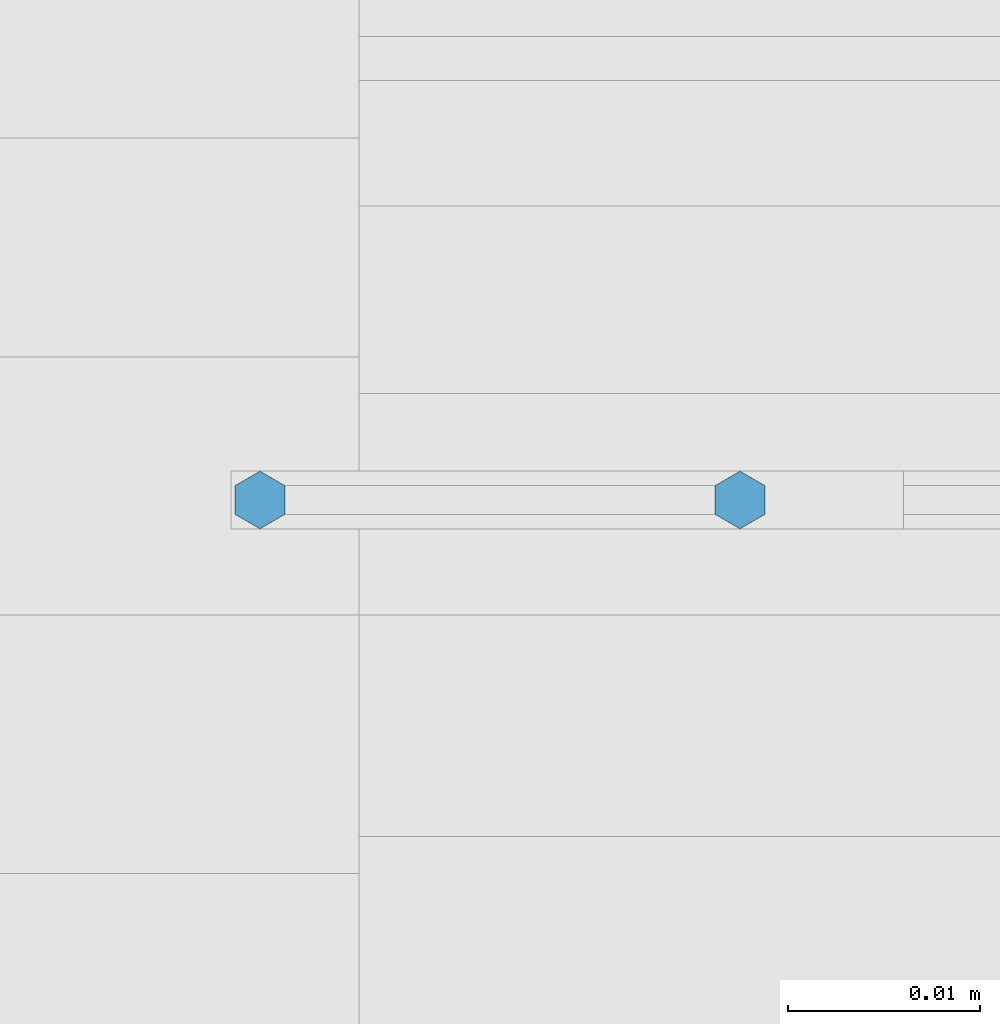
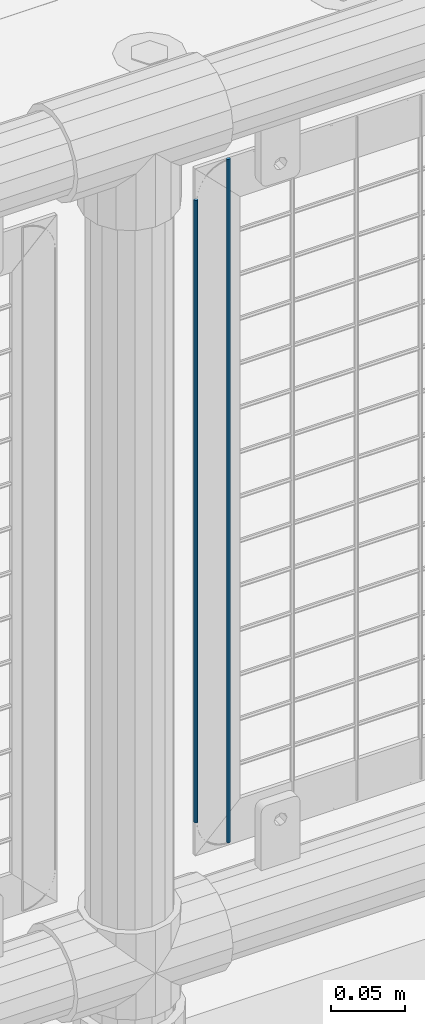
# One storey, part 80 of 257: 2 columns.
"""IFC2X3 building model written with IfcOpenShell, lengths in millimetres."""

import ifcopenshell
import ifcopenshell.guid

model = None  # the IFC model being written
_history = None  # IfcOwnerHistory: only IFC2X3 demands one
_inside = {}  # id of a spatial element -> (the spatial element, [elements in it])
_under = {}  # id of a project, library or spatial element -> (it, [spatial elements below it])
_declared = {}  # id of a project -> (the project, [libraries it declares])
_typed = {}  # id of a type object -> (the type object, [elements of that type])
_made_of = {}  # id of a material, layer set ... -> (it, [elements and type objects made of it])


def new_model(schema):
    """Start an empty IFC model of exactly this schema.

    Asked for "IFC4X3", IfcOpenShell would pick the latest addendum, in which some entities
    have other attributes; the version numbers below select the first issue.
    IFC2X3 requires an IfcOwnerHistory on every rooted entity: one is made here for all.
    """
    global model, _history
    if schema == "IFC4X3":
        model = ifcopenshell.file(schema_version=(4, 3, 0, 0))
    else:
        model = ifcopenshell.file(schema=schema)
    _inside.clear()
    _under.clear()
    _declared.clear()
    _typed.clear()
    _made_of.clear()
    _history = None
    if model.schema == "IFC2X3":
        org = make("IfcOrganization", Name="unknown")
        user = make(
            "IfcPersonAndOrganization",
            ThePerson=make("IfcPerson", FamilyName="unknown"),
            TheOrganization=org,
        )
        app = make(
            "IfcApplication",
            ApplicationDeveloper=org,
            Version="unknown",
            ApplicationFullName="unknown",
            ApplicationIdentifier="unknown",
        )
        _history = make(
            "IfcOwnerHistory",
            OwningUser=user,
            OwningApplication=app,
            ChangeAction="ADDED",
            CreationDate=0,
        )
    return model


def make(cls, **values):
    """One entity of the class cls with the attributes given. An attribute that is None is left unset."""
    return model.create_entity(
        cls, **{name: value for name, value in values.items() if value is not None}
    )


def rooted(cls, **values):
    """An entity with a GlobalId (a new one), such as an element, a storey or a relation."""
    return make(cls, GlobalId=ifcopenshell.guid.new(), OwnerHistory=_history, **values)


def si_unit(unit_type, name, prefix=None):
    """IfcSIUnit, for example si_unit("LENGTHUNIT", "METRE", prefix="MILLI")."""
    return make("IfcSIUnit", UnitType=unit_type, Prefix=prefix, Name=name)


def assignment(units):
    """IfcUnitAssignment: the units of a project."""
    return None if units is None else make("IfcUnitAssignment", Units=units)


def point(xyz):
    """IfcCartesianPoint."""
    return None if xyz is None else make("IfcCartesianPoint", Coordinates=xyz)


def direction(xyz):
    """IfcDirection."""
    return None if xyz is None else make("IfcDirection", DirectionRatios=xyz)


def frame(location, z_axis=None, x_axis=None):
    """IfcAxis2Placement3D, a coordinate frame: its origin and axes. An axis left out is left unset."""
    return make(
        "IfcAxis2Placement3D",
        Location=point(location),
        Axis=direction(z_axis),
        RefDirection=direction(x_axis),
    )


def origin_with_axes():
    """The frame at (0, 0, 0) with the z axis (0, 0, 1) and the x axis (1, 0, 0) written out."""
    return frame((0.0, 0.0, 0.0), z_axis=(0.0, 0.0, 1.0), x_axis=(1.0, 0.0, 0.0))


def place(relative_to, where):
    """IfcLocalPlacement: puts the frame where relative to a parent placement (None: the world)."""
    return make(
        "IfcLocalPlacement", PlacementRelTo=relative_to, RelativePlacement=where
    )


def context(
    kind, dimensions, precision=None, world=None, true_north=None, identifier=None
):
    """IfcGeometricRepresentationContext, for example the 3D "Model" context."""
    return make(
        "IfcGeometricRepresentationContext",
        ContextIdentifier=identifier,
        ContextType=kind,
        CoordinateSpaceDimension=dimensions,
        Precision=precision,
        WorldCoordinateSystem=world,
        TrueNorth=true_north,
    )


def subcontext(parent, identifier, kind, view, scale=None):
    """IfcGeometricRepresentationSubContext, for example "Body" below "Model"."""
    return make(
        "IfcGeometricRepresentationSubContext",
        ContextIdentifier=identifier,
        ContextType=kind,
        ParentContext=parent,
        TargetScale=scale,
        TargetView=view,
    )


def project(units=None, contexts=None):
    """IfcProject with its units and contexts."""
    return rooted(
        "IfcProject",
        Name="project",
        RepresentationContexts=contexts,
        UnitsInContext=assignment(units),
    )


def spatial(cls, under=None, at=None, **own):
    """A site, building, storey or space (cls), placed at a placement, below another one or the project."""
    s = rooted(cls, ObjectPlacement=at, **own)
    if under is not None:
        _under.setdefault(under.id(), (under, []))[1].append(s)
    return s


def faces_of(points, faces, orient=None, outer=None):
    """IfcFace entities. A face is a list of loops; a loop is a list of indices into points, from 0.

    orient and outer hold one flag for each loop. By default every Orientation is true, the
    first loop of a face is its IfcFaceOuterBound and the others are IfcFaceBound.
    """
    made = []
    for i, loops in enumerate(faces):
        bounds = []
        for j, loop in enumerate(loops):
            is_outer = j == 0 if outer is None else outer[i][j]
            bounds.append(
                make(
                    "IfcFaceOuterBound" if is_outer else "IfcFaceBound",
                    Bound=make("IfcPolyLoop", Polygon=[points[k] for k in loop]),
                    Orientation=True if orient is None else orient[i][j],
                )
            )
        made.append(make("IfcFace", Bounds=bounds))
    return made


def faceted_brep(points, faces, orient=None, outer=None, voids=None):
    """IfcFacetedBrep: a solid bounded by flat faces; with voids (closed shells), ...WithVoids."""
    shared = [point(p) for p in points]
    hull = make("IfcClosedShell", CfsFaces=faces_of(shared, faces, orient, outer))
    if voids is None:
        return make("IfcFacetedBrep", Outer=hull)
    return make(
        "IfcFacetedBrepWithVoids",
        Outer=hull,
        Voids=[
            make(cls, CfsFaces=faces_of(shared, fs, o, b)) for cls, fs, o, b in voids
        ],
    )


def shape(context_of_items, identifier, shape_type, items):
    """IfcShapeRepresentation: the items that make up one representation, for example the "Body"."""
    return make(
        "IfcShapeRepresentation",
        ContextOfItems=context_of_items,
        RepresentationIdentifier=identifier,
        RepresentationType=shape_type,
        Items=items,
    )


def material(Name=None, Category=None):
    """IfcMaterial."""
    return make("IfcMaterial", Name=Name, Category=Category)


def made_of(thing, what):
    """Note that an element or type object is made of a material, layer set ...; save() writes the relation."""
    if what is not None:
        _made_of.setdefault(what.id(), (what, []))[1].append(thing)
    return thing


def type_object(cls, material=None, **own):
    """A type object (cls), such as IfcWallType, which elements share."""
    return made_of(rooted(cls, **own), material)


def element(
    cls,
    number,
    at=None,
    inside=None,
    cuts=None,
    type_object=None,
    material=None,
    context=None,
    identifier="Body",
    shape_type=None,
    held_by="IfcProductDefinitionShape",
    body=None,
    shapes=None,
    **own,
):
    """One element of the class cls, such as IfcWall. Its Tag is "e" and its number.

    at: its placement. inside: the storey or other place that contains it. cuts: it is an
    opening in that element (IfcRelVoidsElement). A single representation is given by context,
    identifier, shape_type and body (its items); several are given by shapes. held_by: the class
    of the entity that holds the representations. save() writes the other relations.
    """
    e = rooted(cls, Tag="e%d" % number, ObjectPlacement=at, **own)
    if body is not None:
        shapes = [shape(context, identifier, shape_type, body)]
    if shapes is not None:
        e.Representation = make(held_by, Representations=shapes)
    if inside is not None:
        _inside.setdefault(inside.id(), (inside, []))[1].append(e)
    if cuts is not None:
        rooted(
            "IfcRelVoidsElement", RelatingBuildingElement=cuts, RelatedOpeningElement=e
        )
    if type_object is not None:
        _typed.setdefault(type_object.id(), (type_object, []))[1].append(e)
    return made_of(e, material)


def aggregate(whole, parts):
    """IfcRelAggregates: a whole, such as a stair, and the parts it consists of."""
    return rooted("IfcRelAggregates", RelatingObject=whole, RelatedObjects=parts)


def save(model, path):
    """Write the relations noted so far, then the file.

    IfcRelAggregates (storeys below a building ...), IfcRelContainedInSpatialStructure (elements
    in a storey), IfcRelDefinesByType, IfcRelAssociatesMaterial and IfcRelDeclares: one each for
    every whole, place, type object, material and project.
    """
    for whole, parts in _under.values():
        aggregate(whole, parts)
    for where, things in _inside.values():
        rooted(
            "IfcRelContainedInSpatialStructure",
            RelatedElements=things,
            RelatingStructure=where,
        )
    for kind, things in _typed.values():
        rooted("IfcRelDefinesByType", RelatedObjects=things, RelatingType=kind)
    for what, things in _made_of.values():
        rooted("IfcRelAssociatesMaterial", RelatedObjects=things, RelatingMaterial=what)
    for by, libraries in _declared.values():
        rooted("IfcRelDeclares", RelatingContext=by, RelatedDefinitions=libraries)
    model.write(path)


model = new_model("IFC2X3")

# Units and contexts
model_context = context("Model", 3, precision=1e-05, world=origin_with_axes())
body_context = subcontext(model_context, "Body", "Model", "MODEL_VIEW")
ifc_project = project(units=[si_unit("LENGTHUNIT", "METRE", prefix="MILLI"), si_unit("AREAUNIT", "SQUARE_METRE"), si_unit("VOLUMEUNIT", "CUBIC_METRE"), si_unit("MASSUNIT", "GRAM", prefix="KILO"), si_unit("TIMEUNIT", "SECOND"), si_unit("PLANEANGLEUNIT", "RADIAN"), si_unit("SOLIDANGLEUNIT", "STERADIAN"), si_unit("THERMODYNAMICTEMPERATUREUNIT", "DEGREE_CELSIUS"), si_unit("LUMINOUSINTENSITYUNIT", "LUMEN")], contexts=[model_context])

# Site, building, storey
site_placement = place(None, origin_with_axes())
site = spatial("IfcSite", under=ifc_project, at=site_placement, CompositionType="ELEMENT")
building_placement = place(site_placement, origin_with_axes())
building = spatial("IfcBuilding", under=site, at=building_placement, Name="Standard", CompositionType="ELEMENT")
storey_placement = place(building_placement, origin_with_axes())
storey = spatial("IfcBuildingStorey", under=building, at=storey_placement, Name="Undefined", CompositionType="ELEMENT", Elevation=0.0)

# Columns
ifc_material = material(Name="Misc_Undefined")
column_type = type_object("IfcColumnType", Name="D3", PredefinedType="NOTDEFINED")
column_1_placement = place(storey_placement, frame((49526.0, 10670.5, 378.020000000002), z_axis=(-1.0, 0.0, 0.0), x_axis=(0.0, 0.0, 1.0)))
element("IfcColumn", 1, at=column_1_placement, inside=storey, type_object=column_type, material=ifc_material, ObjectType="D3", context=body_context, shape_type="Brep", body=[
    faceted_brep([(0.0, -1.5, -5.6843418860808e-14), (0.0, -0.750000000001819, -1.29903810567669), (510.0, -0.75, -1.29903810567339), (510.0, -1.5, 0.0), (7.27595761418343e-12, 0.749999999998181, -1.29903810567669), (510.0, 0.75, -1.29903810567339), (0.0, 1.5, -5.6843418860808e-14), (510.0, 1.5, 0.0), (7.27595761418343e-12, 0.749999999998181, 1.29903810567669), (510.0, 0.75, 1.29903810567339), (0.0, -0.750000000001819, 1.29903810567669), (510.0, -0.75, 1.29903810567339)], [[[0, 1, 2, 3]], [[1, 4, 5, 2]], [[4, 6, 7, 5]], [[6, 8, 9, 7]], [[8, 10, 11, 9]], [[10, 0, 3, 11]], [[5, 7, 9, 11, 3, 2]], [[10, 8, 6, 4, 1, 0]]]),
])
column_2_placement = place(storey_placement, frame((49551.0, 10670.5, 353.020000000002), z_axis=(-1.0, 0.0, 0.0), x_axis=(0.0, 0.0, 1.0)))
element("IfcColumn", 2, at=column_2_placement, inside=storey, type_object=column_type, material=ifc_material, ObjectType="D3", context=body_context, shape_type="Brep", body=[
    faceted_brep([(0.0, -1.5, -5.6843418860808e-14), (0.0, -0.750000000001819, -1.29903810567669), (560.0, -0.75, -1.29903810567339), (560.0, -1.5, 0.0), (7.27595761418343e-12, 0.749999999998181, -1.29903810567669), (560.0, 0.75, -1.29903810567339), (0.0, 1.5, -5.6843418860808e-14), (560.0, 1.5, 0.0), (7.27595761418343e-12, 0.749999999998181, 1.29903810567669), (560.0, 0.75, 1.29903810567339), (0.0, -0.750000000001819, 1.29903810567669), (560.0, -0.75, 1.29903810567339)], [[[0, 1, 2, 3]], [[1, 4, 5, 2]], [[4, 6, 7, 5]], [[6, 8, 9, 7]], [[8, 10, 11, 9]], [[10, 0, 3, 11]], [[5, 7, 9, 11, 3, 2]], [[10, 8, 6, 4, 1, 0]]]),
])

save(model, "model.ifc")
